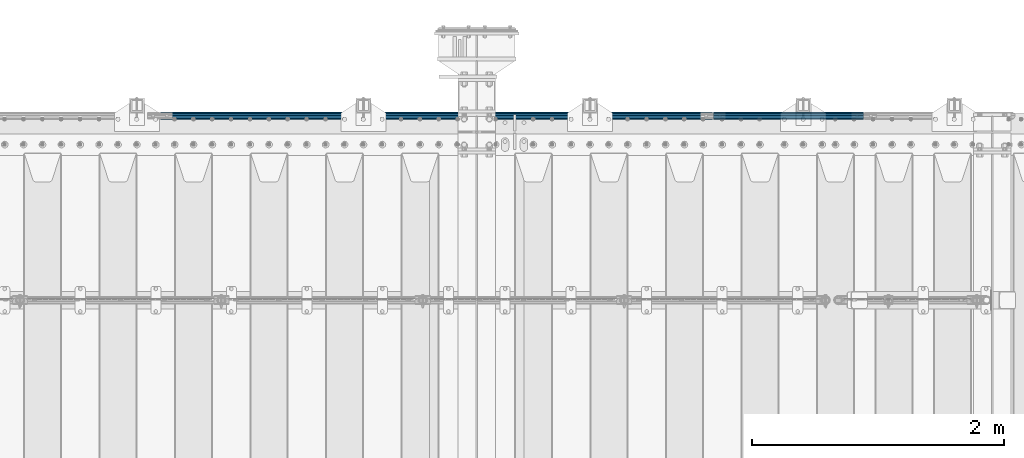
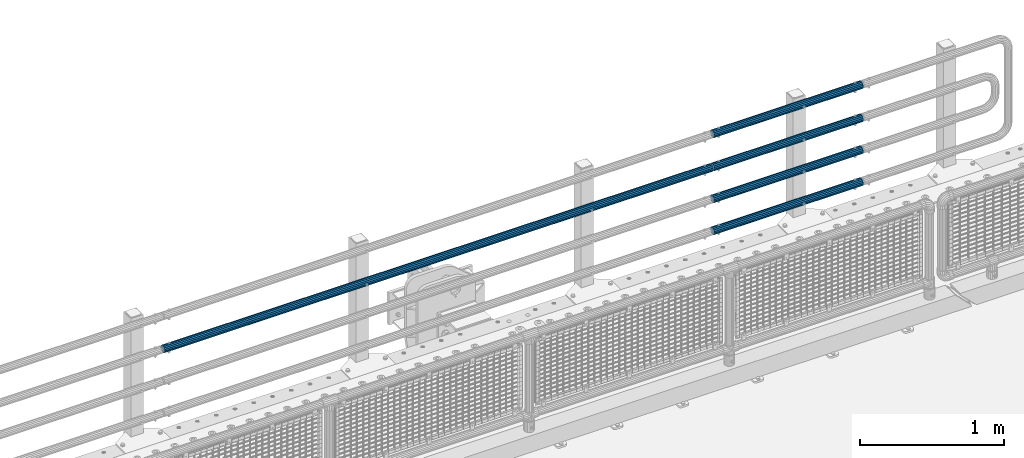
# One storey, part 129 of 257: 5 beams.
"""IFC2X3 building model written with IfcOpenShell, lengths in millimetres."""

from ifc_helpers import new_model, si_unit, frame, origin_with_axes, place, context, subcontext, project, spatial, faceted_brep, material, type_object, element, save


model = new_model("IFC2X3")

# Units and contexts
model_context = context("Model", 3, precision=1e-05, world=origin_with_axes())
body_context = subcontext(model_context, "Body", "Model", "MODEL_VIEW")
ifc_project = project(units=[si_unit("LENGTHUNIT", "METRE", prefix="MILLI"), si_unit("AREAUNIT", "SQUARE_METRE"), si_unit("VOLUMEUNIT", "CUBIC_METRE"), si_unit("MASSUNIT", "GRAM", prefix="KILO"), si_unit("TIMEUNIT", "SECOND"), si_unit("PLANEANGLEUNIT", "RADIAN"), si_unit("SOLIDANGLEUNIT", "STERADIAN"), si_unit("THERMODYNAMICTEMPERATUREUNIT", "DEGREE_CELSIUS"), si_unit("LUMINOUSINTENSITYUNIT", "LUMEN")], contexts=[model_context])

# Site, building, storey
site_placement = place(None, origin_with_axes())
site = spatial("IfcSite", under=ifc_project, at=site_placement, CompositionType="ELEMENT")
building_placement = place(site_placement, origin_with_axes())
building = spatial("IfcBuilding", under=site, at=building_placement, Name="Standard", CompositionType="ELEMENT")
storey_placement = place(building_placement, origin_with_axes())
storey = spatial("IfcBuildingStorey", under=building, at=storey_placement, Name="Undefined", CompositionType="ELEMENT", Elevation=0.0)

# Beams
ifc_material = material()
beam_type = type_object("IfcBeamType", PredefinedType="NOTDEFINED")
beam_1_placement = place(storey_placement, frame((56582.0000000001, 12129.8499999996, 419.849999999725), z_axis=(0.0, -1.0, 0.0), x_axis=(1.0, 0.0, 0.0)))
element("IfcBeam", 1, at=beam_1_placement, inside=storey, type_object=beam_type, material=ifc_material, context=body_context, shape_type="Brep", body=[
    faceted_brep([(0.0, -26.5499999999993, 0.0), (0.0, -24.5290015881747, 10.1602451292931), (1190.0, -24.5290015881747, 10.1602451292929), (1190.0, -26.55, 0.0), (0.0, -18.7736850405036, 18.7736850405028), (1190.0, -18.7736850405028, 18.7736850405036), (0.0, -10.1602451292929, 24.5290015881747), (1190.0, -10.1602451292931, 24.5290015881747), (0.0, 0.0, 26.55), (1190.0, 0.0, 26.5499999999993), (0.0, 10.1602451292929, 24.5290015881747), (1190.0, 10.1602451292932, 24.5290015881747), (0.0, 18.7736850405036, 18.7736850405028), (1190.0, 18.7736850405029, 18.7736850405036), (0.0, 24.5290015881747, 10.1602451292931), (1190.0, 24.5290015881747, 10.1602451292929), (0.0, 26.5499999999993, 0.0), (1190.0, 26.55, 0.0), (0.0, 24.5290015881747, -10.1602451292931), (1190.0, 24.5290015881747, -10.1602451292929), (0.0, 18.7736850405036, -18.7736850405028), (1190.0, 18.7736850405028, -18.7736850405036), (0.0, 10.1602451292929, -24.5290015881747), (1190.0, 10.1602451292931, -24.5290015881747), (0.0, 0.0, -26.55), (1190.0, 0.0, -26.5499999999993), (0.0, -10.1602451292929, -24.5290015881747), (1190.0, -10.1602451292931, -24.5290015881747), (0.0, -18.7736850405036, -18.7736850405028), (1190.0, -18.7736850405028, -18.7736850405036), (0.0, -24.5290015881747, -10.1602451292931), (1190.0, -24.5290015881747, -10.1602451292929), (0.0, -30.1499999999996, 0.0), (0.0, -27.8549679052157, -11.5379054858058), (1190.0, -27.8549679052153, -11.5379054858076), (1190.0, -30.15, 0.0), (0.0, -21.3192694527752, -21.3192694527752), (1190.0, -21.3192694527744, -21.3192694527752), (0.0, -11.5379054858076, -27.8549679052157), (1190.0, -11.5379054858075, -27.8549679052157), (0.0, 0.0, -30.1500000000015), (1190.0, 0.0, -30.1499999999996), (0.0, 11.5379054858076, -27.8549679052157), (1190.0, 11.5379054858075, -27.8549679052157), (0.0, 21.3192694527752, -21.3192694527752), (1190.0, 21.3192694527744, -21.3192694527752), (0.0, 27.8549679052157, -11.5379054858058), (1190.0, 27.8549679052153, -11.5379054858076), (0.0, 30.1499999999996, 0.0), (1190.0, 30.15, 0.0), (0.0, 27.8549679052157, 11.5379054858058), (1190.0, 27.8549679052153, 11.5379054858076), (0.0, 21.3192694527752, 21.3192694527752), (1190.0, 21.3192694527744, 21.3192694527752), (0.0, 11.5379054858076, 27.8549679052157), (1190.0, 11.5379054858075, 27.8549679052157), (0.0, 0.0, 30.1500000000015), (1190.0, 0.0, 30.1499999999996), (0.0, -11.5379054858076, 27.8549679052157), (1190.0, -11.5379054858075, 27.8549679052157), (0.0, -21.3192694527752, 21.3192694527752), (1190.0, -21.3192694527744, 21.3192694527752), (0.0, -27.8549679052157, 11.5379054858058), (1190.0, -27.8549679052153, 11.5379054858076)], [[[0, 1, 2, 3]], [[1, 4, 5, 2]], [[4, 6, 7, 5]], [[6, 8, 9, 7]], [[8, 10, 11, 9]], [[10, 12, 13, 11]], [[12, 14, 15, 13]], [[14, 16, 17, 15]], [[16, 18, 19, 17]], [[18, 20, 21, 19]], [[20, 22, 23, 21]], [[22, 24, 25, 23]], [[24, 26, 27, 25]], [[26, 28, 29, 27]], [[28, 30, 31, 29]], [[30, 0, 3, 31]], [[32, 33, 34, 35]], [[33, 36, 37, 34]], [[36, 38, 39, 37]], [[38, 40, 41, 39]], [[40, 42, 43, 41]], [[42, 44, 45, 43]], [[44, 46, 47, 45]], [[46, 48, 49, 47]], [[48, 50, 51, 49]], [[50, 52, 53, 51]], [[52, 54, 55, 53]], [[54, 56, 57, 55]], [[56, 58, 59, 57]], [[58, 60, 61, 59]], [[60, 62, 63, 61]], [[62, 32, 35, 63]], [[37, 39, 41, 43, 45, 47, 49, 51, 53, 55, 57, 59, 61, 63, 35, 34], [5, 7, 9, 11, 13, 15, 17, 19, 21, 23, 25, 27, 29, 31, 3, 2]], [[62, 60, 58, 56, 54, 52, 50, 48, 46, 44, 42, 40, 38, 36, 33, 32], [30, 28, 26, 24, 22, 20, 18, 16, 14, 12, 10, 8, 6, 4, 1, 0]]]),
])
beam_2_placement = place(storey_placement, frame((56582.0000000001, 12129.8499999996, 149.549999999726), z_axis=(0.0, -1.0, 0.0), x_axis=(1.0, 0.0, 0.0)))
element("IfcBeam", 2, at=beam_2_placement, inside=storey, type_object=beam_type, material=ifc_material, context=body_context, shape_type="Brep", body=[
    faceted_brep([(0.0, -26.5499999999993, 0.0), (0.0, -24.5290015881747, 10.1602451292931), (1190.0, -24.5290015881747, 10.1602451292929), (1190.0, -26.55, 0.0), (0.0, -18.7736850405036, 18.7736850405028), (1190.0, -18.7736850405028, 18.7736850405036), (0.0, -10.1602451292929, 24.5290015881747), (1190.0, -10.1602451292931, 24.5290015881747), (0.0, 0.0, 26.55), (1190.0, 0.0, 26.5499999999993), (0.0, 10.1602451292929, 24.5290015881747), (1190.0, 10.1602451292932, 24.5290015881747), (0.0, 18.7736850405036, 18.7736850405028), (1190.0, 18.7736850405029, 18.7736850405036), (0.0, 24.5290015881747, 10.1602451292931), (1190.0, 24.5290015881747, 10.1602451292929), (0.0, 26.5499999999993, 0.0), (1190.0, 26.55, 0.0), (0.0, 24.5290015881747, -10.1602451292931), (1190.0, 24.5290015881747, -10.1602451292929), (0.0, 18.7736850405036, -18.7736850405028), (1190.0, 18.7736850405028, -18.7736850405036), (0.0, 10.1602451292929, -24.5290015881747), (1190.0, 10.1602451292931, -24.5290015881747), (0.0, 0.0, -26.55), (1190.0, 0.0, -26.5499999999993), (0.0, -10.1602451292929, -24.5290015881747), (1190.0, -10.1602451292931, -24.5290015881747), (0.0, -18.7736850405036, -18.7736850405028), (1190.0, -18.7736850405028, -18.7736850405036), (0.0, -24.5290015881747, -10.1602451292931), (1190.0, -24.5290015881747, -10.1602451292929), (0.0, -30.1499999999996, 0.0), (0.0, -27.8549679052157, -11.5379054858058), (1190.0, -27.8549679052153, -11.5379054858076), (1190.0, -30.15, 0.0), (0.0, -21.3192694527752, -21.3192694527752), (1190.0, -21.3192694527744, -21.3192694527752), (0.0, -11.5379054858076, -27.8549679052157), (1190.0, -11.5379054858075, -27.8549679052157), (0.0, 0.0, -30.1500000000015), (1190.0, 0.0, -30.1499999999996), (0.0, 11.5379054858076, -27.8549679052157), (1190.0, 11.5379054858075, -27.8549679052157), (0.0, 21.3192694527752, -21.3192694527752), (1190.0, 21.3192694527744, -21.3192694527752), (0.0, 27.8549679052157, -11.5379054858058), (1190.0, 27.8549679052153, -11.5379054858076), (0.0, 30.1499999999996, 0.0), (1190.0, 30.15, 0.0), (0.0, 27.8549679052157, 11.5379054858058), (1190.0, 27.8549679052153, 11.5379054858076), (0.0, 21.3192694527752, 21.3192694527752), (1190.0, 21.3192694527744, 21.3192694527752), (0.0, 11.5379054858076, 27.8549679052157), (1190.0, 11.5379054858075, 27.8549679052157), (0.0, 0.0, 30.1500000000015), (1190.0, 0.0, 30.1499999999996), (0.0, -11.5379054858076, 27.8549679052157), (1190.0, -11.5379054858075, 27.8549679052157), (0.0, -21.3192694527752, 21.3192694527752), (1190.0, -21.3192694527744, 21.3192694527752), (0.0, -27.8549679052157, 11.5379054858058), (1190.0, -27.8549679052153, 11.5379054858076)], [[[0, 1, 2, 3]], [[1, 4, 5, 2]], [[4, 6, 7, 5]], [[6, 8, 9, 7]], [[8, 10, 11, 9]], [[10, 12, 13, 11]], [[12, 14, 15, 13]], [[14, 16, 17, 15]], [[16, 18, 19, 17]], [[18, 20, 21, 19]], [[20, 22, 23, 21]], [[22, 24, 25, 23]], [[24, 26, 27, 25]], [[26, 28, 29, 27]], [[28, 30, 31, 29]], [[30, 0, 3, 31]], [[32, 33, 34, 35]], [[33, 36, 37, 34]], [[36, 38, 39, 37]], [[38, 40, 41, 39]], [[40, 42, 43, 41]], [[42, 44, 45, 43]], [[44, 46, 47, 45]], [[46, 48, 49, 47]], [[48, 50, 51, 49]], [[50, 52, 53, 51]], [[52, 54, 55, 53]], [[54, 56, 57, 55]], [[56, 58, 59, 57]], [[58, 60, 61, 59]], [[60, 62, 63, 61]], [[62, 32, 35, 63]], [[37, 39, 41, 43, 45, 47, 49, 51, 53, 55, 57, 59, 61, 63, 35, 34], [5, 7, 9, 11, 13, 15, 17, 19, 21, 23, 25, 27, 29, 31, 3, 2]], [[62, 60, 58, 56, 54, 52, 50, 48, 46, 44, 42, 40, 38, 36, 33, 32], [30, 28, 26, 24, 22, 20, 18, 16, 14, 12, 10, 8, 6, 4, 1, 0]]]),
])
beam_3_placement = place(storey_placement, frame((56582.0000000001, 12129.8499999996, 969.549999999726), z_axis=(0.0, -1.0, 0.0), x_axis=(1.0, 0.0, 0.0)))
element("IfcBeam", 3, at=beam_3_placement, inside=storey, type_object=beam_type, material=ifc_material, context=body_context, shape_type="Brep", body=[
    faceted_brep([(0.0, -26.5499999999993, 0.0), (0.0, -24.5290015881747, 10.1602451292931), (1190.0, -24.5290015881747, 10.1602451292929), (1190.0, -26.55, 0.0), (0.0, -18.7736850405036, 18.7736850405028), (1190.0, -18.7736850405028, 18.7736850405036), (0.0, -10.1602451292929, 24.5290015881747), (1190.0, -10.1602451292931, 24.5290015881747), (0.0, 0.0, 26.55), (1190.0, 0.0, 26.5499999999993), (0.0, 10.1602451292929, 24.5290015881747), (1190.0, 10.1602451292932, 24.5290015881747), (0.0, 18.7736850405036, 18.7736850405028), (1190.0, 18.7736850405029, 18.7736850405036), (0.0, 24.5290015881747, 10.1602451292931), (1190.0, 24.5290015881747, 10.1602451292929), (0.0, 26.5499999999993, 0.0), (1190.0, 26.55, 0.0), (0.0, 24.5290015881747, -10.1602451292931), (1190.0, 24.5290015881747, -10.1602451292929), (0.0, 18.7736850405036, -18.7736850405028), (1190.0, 18.7736850405028, -18.7736850405036), (0.0, 10.1602451292929, -24.5290015881747), (1190.0, 10.1602451292931, -24.5290015881747), (0.0, 0.0, -26.55), (1190.0, 0.0, -26.5499999999993), (0.0, -10.1602451292929, -24.5290015881747), (1190.0, -10.1602451292931, -24.5290015881747), (0.0, -18.7736850405036, -18.7736850405028), (1190.0, -18.7736850405028, -18.7736850405036), (0.0, -24.5290015881747, -10.1602451292931), (1190.0, -24.5290015881747, -10.1602451292929), (0.0, -30.1499999999996, 0.0), (0.0, -27.8549679052157, -11.5379054858058), (1190.0, -27.8549679052153, -11.5379054858076), (1190.0, -30.15, 0.0), (0.0, -21.3192694527752, -21.3192694527752), (1190.0, -21.3192694527744, -21.3192694527752), (0.0, -11.5379054858076, -27.8549679052157), (1190.0, -11.5379054858075, -27.8549679052157), (0.0, 0.0, -30.1500000000015), (1190.0, 0.0, -30.1499999999996), (0.0, 11.5379054858076, -27.8549679052157), (1190.0, 11.5379054858075, -27.8549679052157), (0.0, 21.3192694527752, -21.3192694527752), (1190.0, 21.3192694527744, -21.3192694527752), (0.0, 27.8549679052157, -11.5379054858058), (1190.0, 27.8549679052153, -11.5379054858076), (0.0, 30.1499999999996, 0.0), (1190.0, 30.15, 0.0), (0.0, 27.8549679052157, 11.5379054858058), (1190.0, 27.8549679052153, 11.5379054858076), (0.0, 21.3192694527752, 21.3192694527752), (1190.0, 21.3192694527744, 21.3192694527752), (0.0, 11.5379054858076, 27.8549679052157), (1190.0, 11.5379054858075, 27.8549679052157), (0.0, 0.0, 30.1500000000015), (1190.0, 0.0, 30.1499999999996), (0.0, -11.5379054858076, 27.8549679052157), (1190.0, -11.5379054858075, 27.8549679052157), (0.0, -21.3192694527752, 21.3192694527752), (1190.0, -21.3192694527744, 21.3192694527752), (0.0, -27.8549679052157, 11.5379054858058), (1190.0, -27.8549679052153, 11.5379054858076)], [[[0, 1, 2, 3]], [[1, 4, 5, 2]], [[4, 6, 7, 5]], [[6, 8, 9, 7]], [[8, 10, 11, 9]], [[10, 12, 13, 11]], [[12, 14, 15, 13]], [[14, 16, 17, 15]], [[16, 18, 19, 17]], [[18, 20, 21, 19]], [[20, 22, 23, 21]], [[22, 24, 25, 23]], [[24, 26, 27, 25]], [[26, 28, 29, 27]], [[28, 30, 31, 29]], [[30, 0, 3, 31]], [[32, 33, 34, 35]], [[33, 36, 37, 34]], [[36, 38, 39, 37]], [[38, 40, 41, 39]], [[40, 42, 43, 41]], [[42, 44, 45, 43]], [[44, 46, 47, 45]], [[46, 48, 49, 47]], [[48, 50, 51, 49]], [[50, 52, 53, 51]], [[52, 54, 55, 53]], [[54, 56, 57, 55]], [[56, 58, 59, 57]], [[58, 60, 61, 59]], [[60, 62, 63, 61]], [[62, 32, 35, 63]], [[37, 39, 41, 43, 45, 47, 49, 51, 53, 55, 57, 59, 61, 63, 35, 34], [5, 7, 9, 11, 13, 15, 17, 19, 21, 23, 25, 27, 29, 31, 3, 2]], [[62, 60, 58, 56, 54, 52, 50, 48, 46, 44, 42, 40, 38, 36, 33, 32], [30, 28, 26, 24, 22, 20, 18, 16, 14, 12, 10, 8, 6, 4, 1, 0]]]),
])
beam_4_placement = place(storey_placement, frame((56582.0000000001, 12129.8499999996, 689.549999999726), z_axis=(0.0, -1.0, 0.0), x_axis=(1.0, 0.0, 0.0)))
element("IfcBeam", 4, at=beam_4_placement, inside=storey, type_object=beam_type, material=ifc_material, context=body_context, shape_type="Brep", body=[
    faceted_brep([(0.0, -26.5499999999993, 0.0), (0.0, -24.5290015881747, 10.1602451292931), (1190.0, -24.5290015881747, 10.1602451292929), (1190.0, -26.55, 0.0), (0.0, -18.7736850405036, 18.7736850405028), (1190.0, -18.7736850405028, 18.7736850405036), (0.0, -10.1602451292929, 24.5290015881747), (1190.0, -10.1602451292931, 24.5290015881747), (0.0, 0.0, 26.55), (1190.0, 0.0, 26.5499999999993), (0.0, 10.1602451292929, 24.5290015881747), (1190.0, 10.1602451292932, 24.5290015881747), (0.0, 18.7736850405036, 18.7736850405028), (1190.0, 18.7736850405029, 18.7736850405036), (0.0, 24.5290015881747, 10.1602451292931), (1190.0, 24.5290015881747, 10.1602451292929), (0.0, 26.5499999999993, 0.0), (1190.0, 26.55, 0.0), (0.0, 24.5290015881747, -10.1602451292931), (1190.0, 24.5290015881747, -10.1602451292929), (0.0, 18.7736850405036, -18.7736850405028), (1190.0, 18.7736850405028, -18.7736850405036), (0.0, 10.1602451292929, -24.5290015881747), (1190.0, 10.1602451292931, -24.5290015881747), (0.0, 0.0, -26.55), (1190.0, 0.0, -26.5499999999993), (0.0, -10.1602451292929, -24.5290015881747), (1190.0, -10.1602451292931, -24.5290015881747), (0.0, -18.7736850405036, -18.7736850405028), (1190.0, -18.7736850405028, -18.7736850405036), (0.0, -24.5290015881747, -10.1602451292931), (1190.0, -24.5290015881747, -10.1602451292929), (0.0, -30.1499999999996, 0.0), (0.0, -27.8549679052157, -11.5379054858058), (1190.0, -27.8549679052153, -11.5379054858076), (1190.0, -30.15, 0.0), (0.0, -21.3192694527752, -21.3192694527752), (1190.0, -21.3192694527744, -21.3192694527752), (0.0, -11.5379054858076, -27.8549679052157), (1190.0, -11.5379054858075, -27.8549679052157), (0.0, 0.0, -30.1500000000015), (1190.0, 0.0, -30.1499999999996), (0.0, 11.5379054858076, -27.8549679052157), (1190.0, 11.5379054858075, -27.8549679052157), (0.0, 21.3192694527752, -21.3192694527752), (1190.0, 21.3192694527744, -21.3192694527752), (0.0, 27.8549679052157, -11.5379054858058), (1190.0, 27.8549679052153, -11.5379054858076), (0.0, 30.1499999999996, 0.0), (1190.0, 30.15, 0.0), (0.0, 27.8549679052157, 11.5379054858058), (1190.0, 27.8549679052153, 11.5379054858076), (0.0, 21.3192694527752, 21.3192694527752), (1190.0, 21.3192694527744, 21.3192694527752), (0.0, 11.5379054858076, 27.8549679052157), (1190.0, 11.5379054858075, 27.8549679052157), (0.0, 0.0, 30.1500000000015), (1190.0, 0.0, 30.1499999999996), (0.0, -11.5379054858076, 27.8549679052157), (1190.0, -11.5379054858075, 27.8549679052157), (0.0, -21.3192694527752, 21.3192694527752), (1190.0, -21.3192694527744, 21.3192694527752), (0.0, -27.8549679052157, 11.5379054858058), (1190.0, -27.8549679052153, 11.5379054858076)], [[[0, 1, 2, 3]], [[1, 4, 5, 2]], [[4, 6, 7, 5]], [[6, 8, 9, 7]], [[8, 10, 11, 9]], [[10, 12, 13, 11]], [[12, 14, 15, 13]], [[14, 16, 17, 15]], [[16, 18, 19, 17]], [[18, 20, 21, 19]], [[20, 22, 23, 21]], [[22, 24, 25, 23]], [[24, 26, 27, 25]], [[26, 28, 29, 27]], [[28, 30, 31, 29]], [[30, 0, 3, 31]], [[32, 33, 34, 35]], [[33, 36, 37, 34]], [[36, 38, 39, 37]], [[38, 40, 41, 39]], [[40, 42, 43, 41]], [[42, 44, 45, 43]], [[44, 46, 47, 45]], [[46, 48, 49, 47]], [[48, 50, 51, 49]], [[50, 52, 53, 51]], [[52, 54, 55, 53]], [[54, 56, 57, 55]], [[56, 58, 59, 57]], [[58, 60, 61, 59]], [[60, 62, 63, 61]], [[62, 32, 35, 63]], [[37, 39, 41, 43, 45, 47, 49, 51, 53, 55, 57, 59, 61, 63, 35, 34], [5, 7, 9, 11, 13, 15, 17, 19, 21, 23, 25, 27, 29, 31, 3, 2]], [[62, 60, 58, 56, 54, 52, 50, 48, 46, 44, 42, 40, 38, 36, 33, 32], [30, 28, 26, 24, 22, 20, 18, 16, 14, 12, 10, 8, 6, 4, 1, 0]]]),
])
beam_5_placement = place(storey_placement, frame((56571.9999999999, 12129.8500000002, 689.849999999725), z_axis=(0.0, 0.0, -1.0), x_axis=(-1.0, 0.0, 0.0)))
element("IfcBeam", 5, at=beam_5_placement, inside=storey, type_object=beam_type, material=ifc_material, context=body_context, shape_type="Brep", body=[
    faceted_brep([(0.0, -26.5499999999993, 0.0), (0.0, -24.5290015881747, 10.1602451292931), (4384.0, -24.5290015881747, 10.1602451292931), (4384.0, -26.5499999999993, 0.0), (0.0, -18.7736850405036, 18.7736850405028), (4384.0, -18.7736850405036, 18.7736850405028), (0.0, -10.1602451292929, 24.5290015881747), (4384.0, -10.1602451292929, 24.5290015881747), (0.0, 0.0, 26.55), (4384.0, 0.0, 26.55), (0.0, 10.1602451292929, 24.5290015881747), (4384.0, 10.1602451292929, 24.5290015881747), (0.0, 18.7736850405036, 18.7736850405028), (4384.0, 18.7736850405036, 18.7736850405028), (0.0, 24.5290015881747, 10.1602451292931), (4384.0, 24.5290015881747, 10.1602451292931), (0.0, 26.5499999999993, 0.0), (4384.0, 26.5499999999993, 0.0), (0.0, 24.5290015881747, -10.1602451292931), (4384.0, 24.5290015881747, -10.1602451292931), (0.0, 18.7736850405036, -18.7736850405028), (4384.0, 18.7736850405036, -18.7736850405028), (0.0, 10.1602451292929, -24.5290015881747), (4384.0, 10.1602451292929, -24.5290015881747), (0.0, 0.0, -26.55), (4384.0, 0.0, -26.55), (0.0, -10.1602451292929, -24.5290015881747), (4384.0, -10.1602451292929, -24.5290015881747), (0.0, -18.7736850405036, -18.7736850405028), (4384.0, -18.7736850405036, -18.7736850405028), (0.0, -24.5290015881747, -10.1602451292931), (4384.0, -24.5290015881747, -10.1602451292931), (0.0, -30.1499999999996, 0.0), (0.0, -27.8549679052157, -11.5379054858058), (4384.0, -27.8549679052157, -11.5379054858075), (4384.0, -30.1499999999996, 0.0), (0.0, -21.3192694527752, -21.3192694527752), (4384.0, -21.3192694527752, -21.3192694527744), (0.0, -11.5379054858076, -27.8549679052157), (4384.0, -11.5379054858076, -27.8549679052153), (0.0, 0.0, -30.1500000000015), (4384.0, 0.0, -30.15), (0.0, 11.5379054858076, -27.8549679052157), (4384.0, 11.5379054858076, -27.8549679052153), (0.0, 21.3192694527752, -21.3192694527752), (4384.0, 21.3192694527752, -21.3192694527744), (0.0, 27.8549679052157, -11.5379054858058), (4384.0, 27.8549679052157, -11.5379054858074), (0.0, 30.1499999999996, 0.0), (4384.0, 30.1499999999996, 0.0), (0.0, 27.8549679052157, 11.5379054858058), (4384.0, 27.8549679052157, 11.5379054858075), (0.0, 21.3192694527752, 21.3192694527752), (4384.0, 21.3192694527752, 21.3192694527744), (0.0, 11.5379054858076, 27.8549679052157), (4384.0, 11.5379054858076, 27.8549679052153), (0.0, 0.0, 30.1500000000015), (4384.0, 0.0, 30.15), (0.0, -11.5379054858076, 27.8549679052157), (4384.0, -11.5379054858076, 27.8549679052153), (0.0, -21.3192694527752, 21.3192694527752), (4384.0, -21.3192694527752, 21.3192694527744), (0.0, -27.8549679052157, 11.5379054858058), (4384.0, -27.8549679052157, 11.5379054858075)], [[[0, 1, 2, 3]], [[1, 4, 5, 2]], [[4, 6, 7, 5]], [[6, 8, 9, 7]], [[8, 10, 11, 9]], [[10, 12, 13, 11]], [[12, 14, 15, 13]], [[14, 16, 17, 15]], [[16, 18, 19, 17]], [[18, 20, 21, 19]], [[20, 22, 23, 21]], [[22, 24, 25, 23]], [[24, 26, 27, 25]], [[26, 28, 29, 27]], [[28, 30, 31, 29]], [[30, 0, 3, 31]], [[32, 33, 34, 35]], [[33, 36, 37, 34]], [[36, 38, 39, 37]], [[38, 40, 41, 39]], [[40, 42, 43, 41]], [[42, 44, 45, 43]], [[44, 46, 47, 45]], [[46, 48, 49, 47]], [[48, 50, 51, 49]], [[50, 52, 53, 51]], [[52, 54, 55, 53]], [[54, 56, 57, 55]], [[56, 58, 59, 57]], [[58, 60, 61, 59]], [[60, 62, 63, 61]], [[62, 32, 35, 63]], [[37, 39, 41, 43, 45, 47, 49, 51, 53, 55, 57, 59, 61, 63, 35, 34], [5, 7, 9, 11, 13, 15, 17, 19, 21, 23, 25, 27, 29, 31, 3, 2]], [[62, 60, 58, 56, 54, 52, 50, 48, 46, 44, 42, 40, 38, 36, 33, 32], [30, 28, 26, 24, 22, 20, 18, 16, 14, 12, 10, 8, 6, 4, 1, 0]]]),
])

save(model, "model.ifc")
